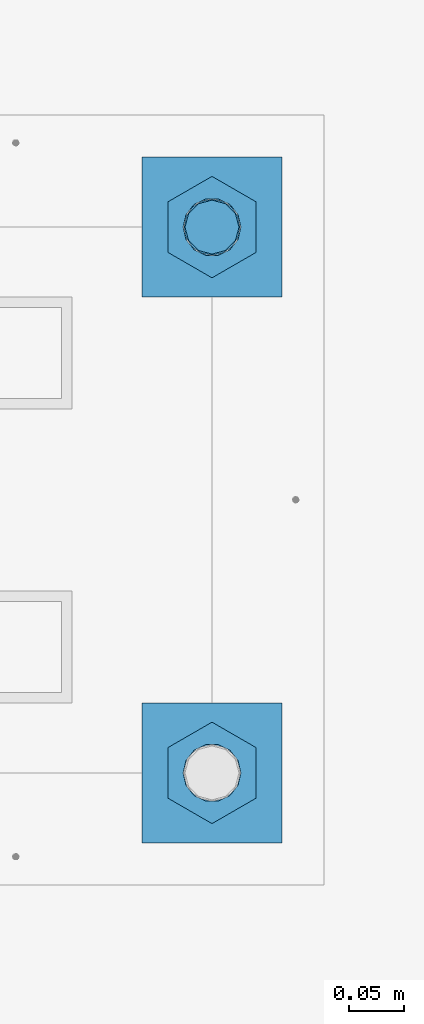
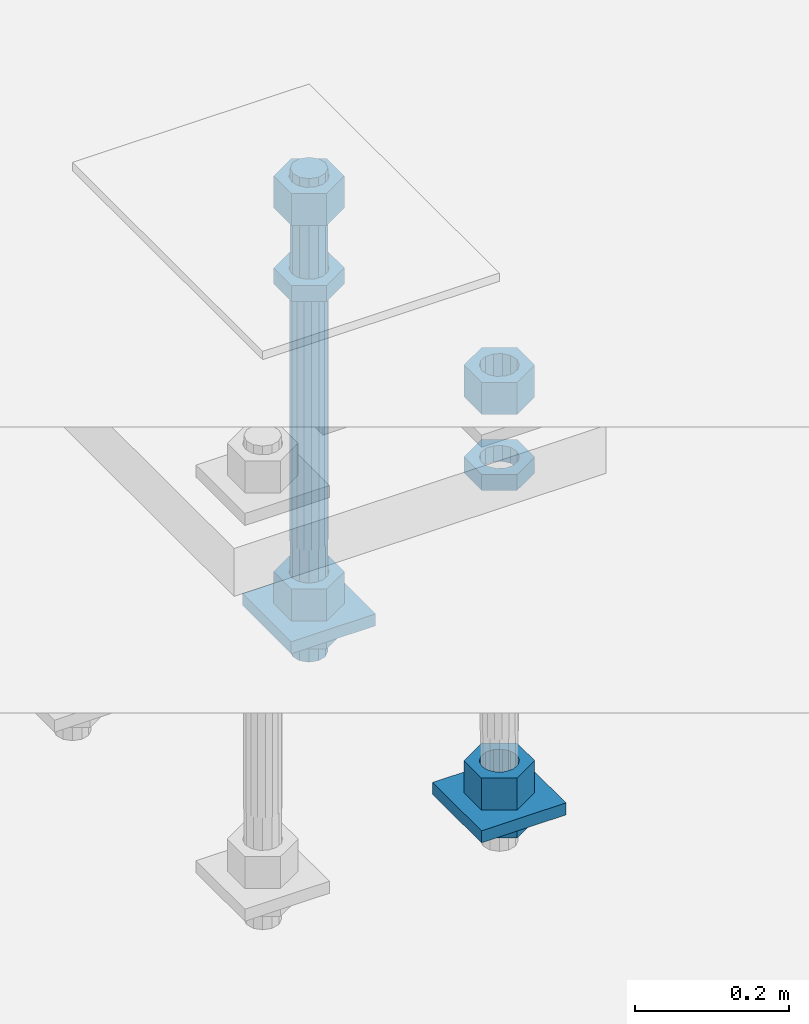
# One storey, part 2621 of 3843: 11 beams, 1 element without a shape of its own.
"""IFC2X3 building model written with IfcOpenShell, lengths in millimetres."""

from ifc_helpers import new_model, si_unit, frame, origin_with_axes, place, context, subcontext, project, spatial, faceted_brep, material, type_object, element, aggregate, save


model = new_model("IFC2X3")

# Units and contexts
model_context = context("Model", 3, precision=1e-05, world=origin_with_axes())
body_context = subcontext(model_context, "Body", "Model", "MODEL_VIEW")
ifc_project = project(units=[si_unit("LENGTHUNIT", "METRE", prefix="MILLI"), si_unit("AREAUNIT", "SQUARE_METRE"), si_unit("VOLUMEUNIT", "CUBIC_METRE"), si_unit("MASSUNIT", "GRAM", prefix="KILO"), si_unit("TIMEUNIT", "SECOND"), si_unit("PLANEANGLEUNIT", "RADIAN"), si_unit("SOLIDANGLEUNIT", "STERADIAN"), si_unit("THERMODYNAMICTEMPERATUREUNIT", "DEGREE_CELSIUS"), si_unit("LUMINOUSINTENSITYUNIT", "LUMEN")], contexts=[model_context])

# Site, building, storey
site_placement = place(None, origin_with_axes())
site = spatial("IfcSite", under=ifc_project, at=site_placement, CompositionType="ELEMENT")
building_placement = place(site_placement, origin_with_axes())
building = spatial("IfcBuilding", under=site, at=building_placement, Name="Undefined", CompositionType="ELEMENT")
storey_placement = place(building_placement, origin_with_axes())
storey = spatial("IfcBuildingStorey", under=building, at=storey_placement, Name="Undefined", CompositionType="ELEMENT", Elevation=0.0)

# Assembly, beams
assembly_placement = place(storey_placement, origin_with_axes())
assembly = element("IfcElementAssembly", 1, at=assembly_placement, inside=storey, Name="TEMPLATE", AssemblyPlace="NOTDEFINED", PredefinedType="RIGID_FRAME")
ifc_material_1 = material(Name="STEEL/A572-50")
beam_type_1 = type_object("IfcBeamType", PredefinedType="NOTDEFINED")
beam_1_placement = place(assembly_placement, frame((116217.700001526, 247.649999999994, 29244.925), z_axis=(0.0, -1.0, 0.0), x_axis=(1.0, 0.0, 0.0)))
beam_1 = element("IfcBeam", 2, at=beam_1_placement, type_object=beam_type_1, material=ifc_material_1, Name="WASHER_PLATE", context=body_context, shape_type="Brep", body=[
    faceted_brep([(0.0, 9.52500000000146, -63.5), (0.0, 9.52500000000146, 63.5), (127.0, 9.52500000000146, 63.5), (127.0, 9.52500000000146, -63.5), (0.0, -9.52500000000146, 63.5), (127.0, -9.52500000000146, 63.5), (0.0, -9.52500000000146, -63.5), (127.0, -9.52500000000146, -63.5)], [[[0, 1, 2, 3]], [[1, 4, 5, 2]], [[4, 6, 7, 5]], [[6, 0, 3, 7]], [[5, 7, 3, 2]], [[6, 4, 1, 0]]]),
])
beam_2_placement = place(assembly_placement, frame((116217.700001526, -247.649999999994, 29244.925), z_axis=(0.0, -1.0, 0.0), x_axis=(1.0, 0.0, 0.0)))
beam_2 = element("IfcBeam", 3, at=beam_2_placement, type_object=beam_type_1, material=ifc_material_1, Name="WASHER_PLATE", context=body_context, shape_type="Brep", body=[
    faceted_brep([(0.0, 9.52500000000146, -63.5), (0.0, 9.52500000000146, 63.5), (127.0, 9.52500000000146, 63.5), (127.0, 9.52500000000146, -63.5), (0.0, -9.52500000000146, 63.5), (127.0, -9.52500000000146, 63.5), (0.0, -9.52500000000146, -63.5), (127.0, -9.52500000000146, -63.5)], [[[0, 1, 2, 3]], [[1, 4, 5, 2]], [[4, 6, 7, 5]], [[6, 0, 3, 7]], [[5, 7, 3, 2]], [[6, 4, 1, 0]]]),
])
ifc_material_2 = material(Name="STEEL/A36")
beam_type_2 = type_object("IfcBeamType", Name="2_HALF_NUT", PredefinedType="NOTDEFINED")
beam_3_placement = place(assembly_placement, frame((116281.200001526, 247.649999999994, 29787.85), z_axis=(1.0, 0.0, 0.0), x_axis=(0.0, 0.0, -1.0)))
beam_3 = element("IfcBeam", 4, at=beam_3_placement, type_object=beam_type_2, material=ifc_material_2, Name="NUT", ObjectType="2_HALF_NUT", context=body_context, shape_type="Brep", body=[
    faceted_brep([(0.0, -46.0369987487793, 0.0), (0.0, -23.0184993743896, -39.869213104248), (25.4000000000015, -23.0184993743896, -39.869213104248), (25.4000000000015, -46.0369987487793, 0.0), (0.0, 23.0184993743896, -39.869213104248), (25.4000000000015, 23.0184993743896, -39.869213104248), (0.0, 46.0369987487793, 0.0), (25.4000000000015, 46.0369987487793, 0.0), (0.0, 23.0184993743896, 39.869213104248), (25.4000000000015, 23.0184993743896, 39.869213104248), (0.0, -23.0184993743896, 39.869213104248), (25.4000000000015, -23.0184993743896, 39.869213104248), (0.0, 0.0, 26.1940002441406), (0.0, 11.3650617044477, 23.5999013092805), (25.4000000000015, 11.3650617044477, 23.5999013092805), (25.4000000000015, 0.0, 26.1940002441406), (0.0, 20.4791109456419, 16.3316083006721), (25.4000000000015, 20.4791109456419, 16.3316083006721), (0.0, 25.5370200498292, 5.82867859874386), (25.4000000000015, 25.5370200498292, 5.82867859874386), (0.0, 25.5370200498292, -5.82867859874386), (25.4000000000015, 25.5370200498292, -5.82867859874386), (0.0, 20.4791109456419, -16.3316083006721), (25.4000000000015, 20.4791109456419, -16.3316083006721), (0.0, 11.3650617044477, -23.5999013092805), (25.4000000000015, 11.3650617044477, -23.5999013092805), (0.0, 0.0, -26.1940002441406), (25.4000000000015, 0.0, -26.1940002441406), (0.0, -11.3650617044477, -23.5999013092805), (25.4000000000015, -11.3650617044477, -23.5999013092805), (0.0, -20.4791109456419, -16.3316083006721), (25.4000000000015, -20.4791109456419, -16.3316083006721), (0.0, -25.5370200498292, -5.82867859874386), (25.4000000000015, -25.5370200498292, -5.82867859874386), (0.0, -25.5370200498292, 5.82867859874386), (25.4000000000015, -25.5370200498292, 5.82867859874386), (0.0, -20.4791109456419, 16.3316083006721), (25.4000000000015, -20.4791109456419, 16.3316083006721), (0.0, -11.3650617044477, 23.5999013092805), (25.4000000000015, -11.3650617044477, 23.5999013092805)], [[[0, 1, 2, 3]], [[1, 4, 5, 2]], [[4, 6, 7, 5]], [[6, 8, 9, 7]], [[8, 10, 11, 9]], [[10, 0, 3, 11]], [[12, 13, 14, 15]], [[13, 16, 17, 14]], [[16, 18, 19, 17]], [[18, 20, 21, 19]], [[20, 22, 23, 21]], [[22, 24, 25, 23]], [[24, 26, 27, 25]], [[26, 28, 29, 27]], [[28, 30, 31, 29]], [[30, 32, 33, 31]], [[32, 34, 35, 33]], [[34, 36, 37, 35]], [[36, 38, 39, 37]], [[38, 12, 15, 39]], [[5, 7, 9, 11, 3, 2], [17, 19, 21, 23, 25, 27, 29, 31, 33, 35, 37, 39, 15, 14]], [[10, 8, 6, 4, 1, 0], [38, 36, 34, 32, 30, 28, 26, 24, 22, 20, 18, 16, 13, 12]]]),
])
beam_4_placement = place(assembly_placement, frame((116281.200001526, 247.649999999994, 29235.4), z_axis=(1.0, 0.0, 0.0), x_axis=(0.0, 0.0, -1.0)))
beam_4 = element("IfcBeam", 5, at=beam_4_placement, type_object=beam_type_2, material=ifc_material_2, Name="NUT", ObjectType="2_HALF_NUT", context=body_context, shape_type="Brep", body=[
    faceted_brep([(0.0, -46.0369987487793, 0.0), (0.0, -23.0184993743896, -39.869213104248), (25.4000000000015, -23.0184993743896, -39.869213104248), (25.4000000000015, -46.0369987487793, 0.0), (0.0, 23.0184993743896, -39.869213104248), (25.4000000000015, 23.0184993743896, -39.869213104248), (0.0, 46.0369987487793, 0.0), (25.4000000000015, 46.0369987487793, 0.0), (0.0, 23.0184993743896, 39.869213104248), (25.4000000000015, 23.0184993743896, 39.869213104248), (0.0, -23.0184993743896, 39.869213104248), (25.4000000000015, -23.0184993743896, 39.869213104248), (0.0, 0.0, 26.1940002441406), (0.0, 11.3650617044477, 23.5999013092805), (25.4000000000015, 11.3650617044477, 23.5999013092805), (25.4000000000015, 0.0, 26.1940002441406), (0.0, 20.4791109456419, 16.3316083006721), (25.4000000000015, 20.4791109456419, 16.3316083006721), (0.0, 25.5370200498292, 5.82867859874386), (25.4000000000015, 25.5370200498292, 5.82867859874386), (0.0, 25.5370200498292, -5.82867859874386), (25.4000000000015, 25.5370200498292, -5.82867859874386), (0.0, 20.4791109456419, -16.3316083006721), (25.4000000000015, 20.4791109456419, -16.3316083006721), (0.0, 11.3650617044477, -23.5999013092805), (25.4000000000015, 11.3650617044477, -23.5999013092805), (0.0, 0.0, -26.1940002441406), (25.4000000000015, 0.0, -26.1940002441406), (0.0, -11.3650617044477, -23.5999013092805), (25.4000000000015, -11.3650617044477, -23.5999013092805), (0.0, -20.4791109456419, -16.3316083006721), (25.4000000000015, -20.4791109456419, -16.3316083006721), (0.0, -25.5370200498292, -5.82867859874386), (25.4000000000015, -25.5370200498292, -5.82867859874386), (0.0, -25.5370200498292, 5.82867859874386), (25.4000000000015, -25.5370200498292, 5.82867859874386), (0.0, -20.4791109456419, 16.3316083006721), (25.4000000000015, -20.4791109456419, 16.3316083006721), (0.0, -11.3650617044477, 23.5999013092805), (25.4000000000015, -11.3650617044477, 23.5999013092805)], [[[0, 1, 2, 3]], [[1, 4, 5, 2]], [[4, 6, 7, 5]], [[6, 8, 9, 7]], [[8, 10, 11, 9]], [[10, 0, 3, 11]], [[12, 13, 14, 15]], [[13, 16, 17, 14]], [[16, 18, 19, 17]], [[18, 20, 21, 19]], [[20, 22, 23, 21]], [[22, 24, 25, 23]], [[24, 26, 27, 25]], [[26, 28, 29, 27]], [[28, 30, 31, 29]], [[30, 32, 33, 31]], [[32, 34, 35, 33]], [[34, 36, 37, 35]], [[36, 38, 39, 37]], [[38, 12, 15, 39]], [[5, 7, 9, 11, 3, 2], [17, 19, 21, 23, 25, 27, 29, 31, 33, 35, 37, 39, 15, 14]], [[10, 8, 6, 4, 1, 0], [38, 36, 34, 32, 30, 28, 26, 24, 22, 20, 18, 16, 13, 12]]]),
])
beam_5_placement = place(assembly_placement, frame((116281.200001526, -247.649999999994, 29787.85), z_axis=(1.0, 0.0, 0.0), x_axis=(0.0, 0.0, -1.0)))
beam_5 = element("IfcBeam", 6, at=beam_5_placement, type_object=beam_type_2, material=ifc_material_2, Name="NUT", ObjectType="2_HALF_NUT", context=body_context, shape_type="Brep", body=[
    faceted_brep([(0.0, -46.0369987487793, 0.0), (0.0, -23.0184993743896, -39.869213104248), (25.4000000000015, -23.0184993743896, -39.869213104248), (25.4000000000015, -46.0369987487793, 0.0), (0.0, 23.0184993743896, -39.869213104248), (25.4000000000015, 23.0184993743896, -39.869213104248), (0.0, 46.0369987487793, 0.0), (25.4000000000015, 46.0369987487793, 0.0), (0.0, 23.0184993743896, 39.869213104248), (25.4000000000015, 23.0184993743896, 39.869213104248), (0.0, -23.0184993743896, 39.869213104248), (25.4000000000015, -23.0184993743896, 39.869213104248), (0.0, 0.0, 26.1940002441406), (0.0, 11.3650617044477, 23.5999013092805), (25.4000000000015, 11.3650617044477, 23.5999013092805), (25.4000000000015, 0.0, 26.1940002441406), (0.0, 20.4791109456419, 16.3316083006721), (25.4000000000015, 20.4791109456419, 16.3316083006721), (0.0, 25.5370200498292, 5.82867859874386), (25.4000000000015, 25.5370200498292, 5.82867859874386), (0.0, 25.5370200498292, -5.82867859874386), (25.4000000000015, 25.5370200498292, -5.82867859874386), (0.0, 20.4791109456419, -16.3316083006721), (25.4000000000015, 20.4791109456419, -16.3316083006721), (0.0, 11.3650617044477, -23.5999013092805), (25.4000000000015, 11.3650617044477, -23.5999013092805), (0.0, 0.0, -26.1940002441406), (25.4000000000015, 0.0, -26.1940002441406), (0.0, -11.3650617044477, -23.5999013092805), (25.4000000000015, -11.3650617044477, -23.5999013092805), (0.0, -20.4791109456419, -16.3316083006721), (25.4000000000015, -20.4791109456419, -16.3316083006721), (0.0, -25.5370200498292, -5.82867859874386), (25.4000000000015, -25.5370200498292, -5.82867859874386), (0.0, -25.5370200498292, 5.82867859874386), (25.4000000000015, -25.5370200498292, 5.82867859874386), (0.0, -20.4791109456419, 16.3316083006721), (25.4000000000015, -20.4791109456419, 16.3316083006721), (0.0, -11.3650617044477, 23.5999013092805), (25.4000000000015, -11.3650617044477, 23.5999013092805)], [[[0, 1, 2, 3]], [[1, 4, 5, 2]], [[4, 6, 7, 5]], [[6, 8, 9, 7]], [[8, 10, 11, 9]], [[10, 0, 3, 11]], [[12, 13, 14, 15]], [[13, 16, 17, 14]], [[16, 18, 19, 17]], [[18, 20, 21, 19]], [[20, 22, 23, 21]], [[22, 24, 25, 23]], [[24, 26, 27, 25]], [[26, 28, 29, 27]], [[28, 30, 31, 29]], [[30, 32, 33, 31]], [[32, 34, 35, 33]], [[34, 36, 37, 35]], [[36, 38, 39, 37]], [[38, 12, 15, 39]], [[5, 7, 9, 11, 3, 2], [17, 19, 21, 23, 25, 27, 29, 31, 33, 35, 37, 39, 15, 14]], [[10, 8, 6, 4, 1, 0], [38, 36, 34, 32, 30, 28, 26, 24, 22, 20, 18, 16, 13, 12]]]),
])
beam_6_placement = place(assembly_placement, frame((116281.200001526, -247.649999999994, 29235.4), z_axis=(1.0, 0.0, 0.0), x_axis=(0.0, 0.0, -1.0)))
beam_6 = element("IfcBeam", 7, at=beam_6_placement, type_object=beam_type_2, material=ifc_material_2, Name="NUT", ObjectType="2_HALF_NUT", context=body_context, shape_type="Brep", body=[
    faceted_brep([(0.0, -46.0369987487793, 0.0), (0.0, -23.0184993743896, -39.869213104248), (25.4000000000015, -23.0184993743896, -39.869213104248), (25.4000000000015, -46.0369987487793, 0.0), (0.0, 23.0184993743896, -39.869213104248), (25.4000000000015, 23.0184993743896, -39.869213104248), (0.0, 46.0369987487793, 0.0), (25.4000000000015, 46.0369987487793, 0.0), (0.0, 23.0184993743896, 39.869213104248), (25.4000000000015, 23.0184993743896, 39.869213104248), (0.0, -23.0184993743896, 39.869213104248), (25.4000000000015, -23.0184993743896, 39.869213104248), (0.0, 0.0, 26.1940002441406), (0.0, 11.3650617044477, 23.5999013092805), (25.4000000000015, 11.3650617044477, 23.5999013092805), (25.4000000000015, 0.0, 26.1940002441406), (0.0, 20.4791109456419, 16.3316083006721), (25.4000000000015, 20.4791109456419, 16.3316083006721), (0.0, 25.5370200498292, 5.82867859874386), (25.4000000000015, 25.5370200498292, 5.82867859874386), (0.0, 25.5370200498292, -5.82867859874386), (25.4000000000015, 25.5370200498292, -5.82867859874386), (0.0, 20.4791109456419, -16.3316083006721), (25.4000000000015, 20.4791109456419, -16.3316083006721), (0.0, 11.3650617044477, -23.5999013092805), (25.4000000000015, 11.3650617044477, -23.5999013092805), (0.0, 0.0, -26.1940002441406), (25.4000000000015, 0.0, -26.1940002441406), (0.0, -11.3650617044477, -23.5999013092805), (25.4000000000015, -11.3650617044477, -23.5999013092805), (0.0, -20.4791109456419, -16.3316083006721), (25.4000000000015, -20.4791109456419, -16.3316083006721), (0.0, -25.5370200498292, -5.82867859874386), (25.4000000000015, -25.5370200498292, -5.82867859874386), (0.0, -25.5370200498292, 5.82867859874386), (25.4000000000015, -25.5370200498292, 5.82867859874386), (0.0, -20.4791109456419, 16.3316083006721), (25.4000000000015, -20.4791109456419, 16.3316083006721), (0.0, -11.3650617044477, 23.5999013092805), (25.4000000000015, -11.3650617044477, 23.5999013092805)], [[[0, 1, 2, 3]], [[1, 4, 5, 2]], [[4, 6, 7, 5]], [[6, 8, 9, 7]], [[8, 10, 11, 9]], [[10, 0, 3, 11]], [[12, 13, 14, 15]], [[13, 16, 17, 14]], [[16, 18, 19, 17]], [[18, 20, 21, 19]], [[20, 22, 23, 21]], [[22, 24, 25, 23]], [[24, 26, 27, 25]], [[26, 28, 29, 27]], [[28, 30, 31, 29]], [[30, 32, 33, 31]], [[32, 34, 35, 33]], [[34, 36, 37, 35]], [[36, 38, 39, 37]], [[38, 12, 15, 39]], [[5, 7, 9, 11, 3, 2], [17, 19, 21, 23, 25, 27, 29, 31, 33, 35, 37, 39, 15, 14]], [[10, 8, 6, 4, 1, 0], [38, 36, 34, 32, 30, 28, 26, 24, 22, 20, 18, 16, 13, 12]]]),
])
beam_type_3 = type_object("IfcBeamType", Name="2_HEAVY_HEX_NUT", PredefinedType="NOTDEFINED")
beam_7_placement = place(assembly_placement, frame((116281.200001526, 247.649999999994, 29933.9), z_axis=(1.0, 0.0, 0.0), x_axis=(0.0, 0.0, -1.0)))
beam_7 = element("IfcBeam", 8, at=beam_7_placement, type_object=beam_type_3, material=ifc_material_2, Name="NUT", ObjectType="2_HEAVY_HEX_NUT", context=body_context, shape_type="Brep", body=[
    faceted_brep([(0.0, -46.0369987487793, 0.0), (0.0, -23.0184993743896, -39.869213104248), (50.7999999999993, -23.0184993743896, -39.869213104248), (50.7999999999993, -46.0369987487793, 0.0), (0.0, 23.0184993743896, -39.869213104248), (50.7999999999993, 23.0184993743896, -39.869213104248), (0.0, 46.0369987487793, 0.0), (50.7999999999993, 46.0369987487793, 0.0), (0.0, 23.0184993743896, 39.869213104248), (50.7999999999993, 23.0184993743896, 39.869213104248), (0.0, -23.0184993743896, 39.869213104248), (50.7999999999993, -23.0184993743896, 39.869213104248), (0.0, 0.0, 26.1940002441406), (0.0, 11.3650617044477, 23.5999013092805), (50.7999999999993, 11.3650617044477, 23.5999013092805), (50.7999999999993, 0.0, 26.1940002441406), (0.0, 20.4791109456419, 16.3316083006721), (50.7999999999993, 20.4791109456419, 16.3316083006721), (0.0, 25.5370200498292, 5.82867859874386), (50.7999999999993, 25.5370200498292, 5.82867859874386), (0.0, 25.5370200498292, -5.82867859874386), (50.7999999999993, 25.5370200498292, -5.82867859874386), (0.0, 20.4791109456419, -16.3316083006721), (50.7999999999993, 20.4791109456419, -16.3316083006721), (0.0, 11.3650617044477, -23.5999013092805), (50.7999999999993, 11.3650617044477, -23.5999013092805), (0.0, 0.0, -26.1940002441406), (50.7999999999993, 0.0, -26.1940002441406), (0.0, -11.3650617044477, -23.5999013092805), (50.7999999999993, -11.3650617044477, -23.5999013092805), (0.0, -20.4791109456419, -16.3316083006721), (50.7999999999993, -20.4791109456419, -16.3316083006721), (0.0, -25.5370200498292, -5.82867859874386), (50.7999999999993, -25.5370200498292, -5.82867859874386), (0.0, -25.5370200498292, 5.82867859874386), (50.7999999999993, -25.5370200498292, 5.82867859874386), (0.0, -20.4791109456419, 16.3316083006721), (50.7999999999993, -20.4791109456419, 16.3316083006721), (0.0, -11.3650617044477, 23.5999013092805), (50.7999999999993, -11.3650617044477, 23.5999013092805)], [[[0, 1, 2, 3]], [[1, 4, 5, 2]], [[4, 6, 7, 5]], [[6, 8, 9, 7]], [[8, 10, 11, 9]], [[10, 0, 3, 11]], [[12, 13, 14, 15]], [[13, 16, 17, 14]], [[16, 18, 19, 17]], [[18, 20, 21, 19]], [[20, 22, 23, 21]], [[22, 24, 25, 23]], [[24, 26, 27, 25]], [[26, 28, 29, 27]], [[28, 30, 31, 29]], [[30, 32, 33, 31]], [[32, 34, 35, 33]], [[34, 36, 37, 35]], [[36, 38, 39, 37]], [[38, 12, 15, 39]], [[5, 7, 9, 11, 3, 2], [17, 19, 21, 23, 25, 27, 29, 31, 33, 35, 37, 39, 15, 14]], [[10, 8, 6, 4, 1, 0], [38, 36, 34, 32, 30, 28, 26, 24, 22, 20, 18, 16, 13, 12]]]),
])
beam_8_placement = place(assembly_placement, frame((116281.200001526, 247.649999999994, 29305.25), z_axis=(1.0, 0.0, 0.0), x_axis=(0.0, 0.0, -1.0)))
beam_8 = element("IfcBeam", 9, at=beam_8_placement, type_object=beam_type_3, material=ifc_material_2, Name="NUT", ObjectType="2_HEAVY_HEX_NUT", context=body_context, shape_type="Brep", body=[
    faceted_brep([(0.0, -46.0369987487793, 0.0), (0.0, -23.0184993743896, -39.869213104248), (50.7999999999993, -23.0184993743896, -39.869213104248), (50.7999999999993, -46.0369987487793, 0.0), (0.0, 23.0184993743896, -39.869213104248), (50.7999999999993, 23.0184993743896, -39.869213104248), (0.0, 46.0369987487793, 0.0), (50.7999999999993, 46.0369987487793, 0.0), (0.0, 23.0184993743896, 39.869213104248), (50.7999999999993, 23.0184993743896, 39.869213104248), (0.0, -23.0184993743896, 39.869213104248), (50.7999999999993, -23.0184993743896, 39.869213104248), (0.0, 0.0, 26.1940002441406), (0.0, 11.3650617044477, 23.5999013092805), (50.7999999999993, 11.3650617044477, 23.5999013092805), (50.7999999999993, 0.0, 26.1940002441406), (0.0, 20.4791109456419, 16.3316083006721), (50.7999999999993, 20.4791109456419, 16.3316083006721), (0.0, 25.5370200498292, 5.82867859874386), (50.7999999999993, 25.5370200498292, 5.82867859874386), (0.0, 25.5370200498292, -5.82867859874386), (50.7999999999993, 25.5370200498292, -5.82867859874386), (0.0, 20.4791109456419, -16.3316083006721), (50.7999999999993, 20.4791109456419, -16.3316083006721), (0.0, 11.3650617044477, -23.5999013092805), (50.7999999999993, 11.3650617044477, -23.5999013092805), (0.0, 0.0, -26.1940002441406), (50.7999999999993, 0.0, -26.1940002441406), (0.0, -11.3650617044477, -23.5999013092805), (50.7999999999993, -11.3650617044477, -23.5999013092805), (0.0, -20.4791109456419, -16.3316083006721), (50.7999999999993, -20.4791109456419, -16.3316083006721), (0.0, -25.5370200498292, -5.82867859874386), (50.7999999999993, -25.5370200498292, -5.82867859874386), (0.0, -25.5370200498292, 5.82867859874386), (50.7999999999993, -25.5370200498292, 5.82867859874386), (0.0, -20.4791109456419, 16.3316083006721), (50.7999999999993, -20.4791109456419, 16.3316083006721), (0.0, -11.3650617044477, 23.5999013092805), (50.7999999999993, -11.3650617044477, 23.5999013092805)], [[[0, 1, 2, 3]], [[1, 4, 5, 2]], [[4, 6, 7, 5]], [[6, 8, 9, 7]], [[8, 10, 11, 9]], [[10, 0, 3, 11]], [[12, 13, 14, 15]], [[13, 16, 17, 14]], [[16, 18, 19, 17]], [[18, 20, 21, 19]], [[20, 22, 23, 21]], [[22, 24, 25, 23]], [[24, 26, 27, 25]], [[26, 28, 29, 27]], [[28, 30, 31, 29]], [[30, 32, 33, 31]], [[32, 34, 35, 33]], [[34, 36, 37, 35]], [[36, 38, 39, 37]], [[38, 12, 15, 39]], [[5, 7, 9, 11, 3, 2], [17, 19, 21, 23, 25, 27, 29, 31, 33, 35, 37, 39, 15, 14]], [[10, 8, 6, 4, 1, 0], [38, 36, 34, 32, 30, 28, 26, 24, 22, 20, 18, 16, 13, 12]]]),
])
beam_9_placement = place(assembly_placement, frame((116281.200001526, -247.649999999994, 29933.9), z_axis=(1.0, 0.0, 0.0), x_axis=(0.0, 0.0, -1.0)))
beam_9 = element("IfcBeam", 10, at=beam_9_placement, type_object=beam_type_3, material=ifc_material_2, Name="NUT", ObjectType="2_HEAVY_HEX_NUT", context=body_context, shape_type="Brep", body=[
    faceted_brep([(0.0, -46.0369987487793, 0.0), (0.0, -23.0184993743896, -39.869213104248), (50.7999999999993, -23.0184993743896, -39.869213104248), (50.7999999999993, -46.0369987487793, 0.0), (0.0, 23.0184993743896, -39.869213104248), (50.7999999999993, 23.0184993743896, -39.869213104248), (0.0, 46.0369987487793, 0.0), (50.7999999999993, 46.0369987487793, 0.0), (0.0, 23.0184993743896, 39.869213104248), (50.7999999999993, 23.0184993743896, 39.869213104248), (0.0, -23.0184993743896, 39.869213104248), (50.7999999999993, -23.0184993743896, 39.869213104248), (0.0, 0.0, 26.1940002441406), (0.0, 11.3650617044477, 23.5999013092805), (50.7999999999993, 11.3650617044477, 23.5999013092805), (50.7999999999993, 0.0, 26.1940002441406), (0.0, 20.4791109456419, 16.3316083006721), (50.7999999999993, 20.4791109456419, 16.3316083006721), (0.0, 25.5370200498292, 5.82867859874386), (50.7999999999993, 25.5370200498292, 5.82867859874386), (0.0, 25.5370200498292, -5.82867859874386), (50.7999999999993, 25.5370200498292, -5.82867859874386), (0.0, 20.4791109456419, -16.3316083006721), (50.7999999999993, 20.4791109456419, -16.3316083006721), (0.0, 11.3650617044477, -23.5999013092805), (50.7999999999993, 11.3650617044477, -23.5999013092805), (0.0, 0.0, -26.1940002441406), (50.7999999999993, 0.0, -26.1940002441406), (0.0, -11.3650617044477, -23.5999013092805), (50.7999999999993, -11.3650617044477, -23.5999013092805), (0.0, -20.4791109456419, -16.3316083006721), (50.7999999999993, -20.4791109456419, -16.3316083006721), (0.0, -25.5370200498292, -5.82867859874386), (50.7999999999993, -25.5370200498292, -5.82867859874386), (0.0, -25.5370200498292, 5.82867859874386), (50.7999999999993, -25.5370200498292, 5.82867859874386), (0.0, -20.4791109456419, 16.3316083006721), (50.7999999999993, -20.4791109456419, 16.3316083006721), (0.0, -11.3650617044477, 23.5999013092805), (50.7999999999993, -11.3650617044477, 23.5999013092805)], [[[0, 1, 2, 3]], [[1, 4, 5, 2]], [[4, 6, 7, 5]], [[6, 8, 9, 7]], [[8, 10, 11, 9]], [[10, 0, 3, 11]], [[12, 13, 14, 15]], [[13, 16, 17, 14]], [[16, 18, 19, 17]], [[18, 20, 21, 19]], [[20, 22, 23, 21]], [[22, 24, 25, 23]], [[24, 26, 27, 25]], [[26, 28, 29, 27]], [[28, 30, 31, 29]], [[30, 32, 33, 31]], [[32, 34, 35, 33]], [[34, 36, 37, 35]], [[36, 38, 39, 37]], [[38, 12, 15, 39]], [[5, 7, 9, 11, 3, 2], [17, 19, 21, 23, 25, 27, 29, 31, 33, 35, 37, 39, 15, 14]], [[10, 8, 6, 4, 1, 0], [38, 36, 34, 32, 30, 28, 26, 24, 22, 20, 18, 16, 13, 12]]]),
])
beam_10_placement = place(assembly_placement, frame((116281.200001526, -247.649999999994, 29305.25), z_axis=(1.0, 0.0, 0.0), x_axis=(0.0, 0.0, -1.0)))
beam_10 = element("IfcBeam", 11, at=beam_10_placement, type_object=beam_type_3, material=ifc_material_2, Name="NUT", ObjectType="2_HEAVY_HEX_NUT", context=body_context, shape_type="Brep", body=[
    faceted_brep([(0.0, -46.0369987487793, 0.0), (0.0, -23.0184993743896, -39.869213104248), (50.7999999999993, -23.0184993743896, -39.869213104248), (50.7999999999993, -46.0369987487793, 0.0), (0.0, 23.0184993743896, -39.869213104248), (50.7999999999993, 23.0184993743896, -39.869213104248), (0.0, 46.0369987487793, 0.0), (50.7999999999993, 46.0369987487793, 0.0), (0.0, 23.0184993743896, 39.869213104248), (50.7999999999993, 23.0184993743896, 39.869213104248), (0.0, -23.0184993743896, 39.869213104248), (50.7999999999993, -23.0184993743896, 39.869213104248), (0.0, 0.0, 26.1940002441406), (0.0, 11.3650617044477, 23.5999013092805), (50.7999999999993, 11.3650617044477, 23.5999013092805), (50.7999999999993, 0.0, 26.1940002441406), (0.0, 20.4791109456419, 16.3316083006721), (50.7999999999993, 20.4791109456419, 16.3316083006721), (0.0, 25.5370200498292, 5.82867859874386), (50.7999999999993, 25.5370200498292, 5.82867859874386), (0.0, 25.5370200498292, -5.82867859874386), (50.7999999999993, 25.5370200498292, -5.82867859874386), (0.0, 20.4791109456419, -16.3316083006721), (50.7999999999993, 20.4791109456419, -16.3316083006721), (0.0, 11.3650617044477, -23.5999013092805), (50.7999999999993, 11.3650617044477, -23.5999013092805), (0.0, 0.0, -26.1940002441406), (50.7999999999993, 0.0, -26.1940002441406), (0.0, -11.3650617044477, -23.5999013092805), (50.7999999999993, -11.3650617044477, -23.5999013092805), (0.0, -20.4791109456419, -16.3316083006721), (50.7999999999993, -20.4791109456419, -16.3316083006721), (0.0, -25.5370200498292, -5.82867859874386), (50.7999999999993, -25.5370200498292, -5.82867859874386), (0.0, -25.5370200498292, 5.82867859874386), (50.7999999999993, -25.5370200498292, 5.82867859874386), (0.0, -20.4791109456419, 16.3316083006721), (50.7999999999993, -20.4791109456419, 16.3316083006721), (0.0, -11.3650617044477, 23.5999013092805), (50.7999999999993, -11.3650617044477, 23.5999013092805)], [[[0, 1, 2, 3]], [[1, 4, 5, 2]], [[4, 6, 7, 5]], [[6, 8, 9, 7]], [[8, 10, 11, 9]], [[10, 0, 3, 11]], [[12, 13, 14, 15]], [[13, 16, 17, 14]], [[16, 18, 19, 17]], [[18, 20, 21, 19]], [[20, 22, 23, 21]], [[22, 24, 25, 23]], [[24, 26, 27, 25]], [[26, 28, 29, 27]], [[28, 30, 31, 29]], [[30, 32, 33, 31]], [[32, 34, 35, 33]], [[34, 36, 37, 35]], [[36, 38, 39, 37]], [[38, 12, 15, 39]], [[5, 7, 9, 11, 3, 2], [17, 19, 21, 23, 25, 27, 29, 31, 33, 35, 37, 39, 15, 14]], [[10, 8, 6, 4, 1, 0], [38, 36, 34, 32, 30, 28, 26, 24, 22, 20, 18, 16, 13, 12]]]),
])
ifc_material_3 = material()
beam_type_4 = type_object("IfcBeamType", PredefinedType="NOTDEFINED")
beam_11_placement = place(assembly_placement, frame((116281.200001526, 247.649999999994, 29762.45), z_axis=(1.0, 0.0, 0.0), x_axis=(0.0, 0.0, -1.0)))
beam_11 = element("IfcBeam", 12, at=beam_11_placement, type_object=beam_type_4, material=ifc_material_3, Name="ANCHOR_ROD", context=body_context, shape_type="Brep", body=[
    faceted_brep([(-184.150000000001, -21.217622392709, 12.25), (-184.150000000001, -12.2499999999854, 21.2176223927163), (-184.150000000001, 1.45519152283669e-11, 24.5), (-184.150000000001, 12.2500000000146, 21.2176223927163), (-184.150000000001, 21.2176223927381, 12.25), (-184.150000000001, 24.5000000000146, 0.0), (-184.150000000001, 21.2176223927381, -12.25), (-184.150000000001, 12.2500000000146, -21.2176223927163), (-184.150000000001, 1.45519152283669e-11, -24.5), (-184.150000000001, -12.2499999999854, -21.2176223927163), (-184.150000000001, -21.217622392709, -12.25), (-184.150000000001, -24.4999999999854, 0.0), (0.0, 24.5000000000146, 0.0), (0.0, 21.2176223927381, -12.25), (0.0, 12.2500000000146, -21.2176223927163), (0.0, 1.45519152283669e-11, -24.5), (0.0, -12.2499999999854, -21.2176223927163), (0.0, -21.217622392709, -12.25), (0.0, -24.4999999999854, 0.0), (0.0, -21.217622392709, 12.25), (0.0, -12.2499999999854, 21.2176223927163), (0.0, 1.45519152283669e-11, 24.5), (0.0, 12.2500000000146, 21.2176223927163), (0.0, 21.2176223927381, 12.25), (0.0, -23.4665401257807, 9.72015918207035), (0.0, -17.9605122421344, 17.9605122421417), (0.0, -9.72015918207762, 23.466540125788), (0.0, 0.0, 25.4000000000015), (0.0, 9.72015918207762, 23.466540125788), (0.0, 17.9605122421344, 17.9605122421417), (0.0, 23.4665401257807, 9.72015918207035), (0.0, 25.3999996185303, 0.0), (0.0, 23.4665401257807, -9.72015918207035), (0.0, 17.9605122421344, -17.9605122421417), (0.0, 9.72015918207762, -23.466540125788), (0.0, 0.0, -25.4000000000015), (0.0, -9.72015918207762, -23.466540125788), (0.0, -17.9605122421344, -17.9605122421417), (0.0, -23.4665401257807, -9.72015918207035), (0.0, -25.3999996185303, 0.0), (406.399999999998, -25.3999999999942, 0.0), (406.399999999998, -23.4665401257807, 9.72015918207035), (406.399999999998, -17.9605122421344, 17.9605122421417), (406.399999999998, -9.72015918207762, 23.466540125788), (406.399999999998, 0.0, 25.4000000000015), (406.399999999998, 9.72015918207762, 23.466540125788), (406.399999999998, 17.9605122421344, 17.9605122421417), (406.399999999998, 23.4665401257807, 9.72015918207035), (406.399999999998, 25.3999999999942, 0.0), (406.399999999998, 23.4665401257807, -9.72015918207035), (406.399999999998, 17.9605122421344, -17.9605122421417), (406.399999999998, 9.72015918207762, -23.466540125788), (406.399999999998, 0.0, -25.4000000000015), (406.399999999998, -9.72015918207762, -23.466540125788), (406.399999999998, -17.9605122421344, -17.9605122421417), (406.399999999998, -23.4665401257807, -9.72015918207035), (406.399999999998, -12.2499999999854, 21.2176223927163), (406.399999999998, 1.45519152283669e-11, 24.5), (406.399999999998, 12.2500000000146, 21.2176223927163), (406.399999999998, 21.2176223927381, 12.25), (406.399999999998, 24.5000000000146, 0.0), (406.399999999998, 21.2176223927381, -12.25), (406.399999999998, 12.2500000000146, -21.2176223927163), (406.399999999998, 1.45519152283669e-11, -24.5), (406.399999999998, -12.2499999999854, -21.2176223927163), (406.399999999998, -21.217622392709, -12.25), (406.399999999998, -24.4999999999854, 0.0), (406.399999999998, -21.217622392709, 12.25), (584.200000000001, -12.2499999999854, -21.2176223927163), (584.200000000001, 1.45519152283669e-11, -24.5), (584.200000000001, 12.2500000000146, -21.2176223927163), (584.200000000001, 21.2176223927381, -12.25), (584.200000000001, 24.5000000000146, 0.0), (584.200000000001, 21.2176223927381, 12.25), (584.200000000001, 12.2500000000146, 21.2176223927163), (584.200000000001, 1.45519152283669e-11, 24.5), (584.200000000001, -12.2499999999854, 21.2176223927163), (584.200000000001, -21.217622392709, 12.25), (584.200000000001, -24.4999999999854, 0.0), (584.200000000001, -21.217622392709, -12.25)], [[[0, 1, 2, 3, 4, 5, 6, 7, 8, 9, 10, 11]], [[6, 5, 12, 13]], [[7, 6, 13, 14]], [[8, 7, 14, 15]], [[9, 8, 15, 16]], [[10, 9, 16, 17]], [[11, 10, 17, 18]], [[0, 11, 18, 19]], [[1, 0, 19, 20]], [[2, 1, 20, 21]], [[3, 2, 21, 22]], [[4, 3, 22, 23]], [[5, 4, 23, 12]], [[24, 25, 26, 27, 28, 29, 30, 31, 32, 33, 34, 35, 36, 37, 38, 39], [22, 21, 20, 19, 18, 17, 16, 15, 14, 13, 12, 23]], [[24, 39, 40, 41]], [[25, 24, 41, 42]], [[26, 25, 42, 43]], [[27, 26, 43, 44]], [[28, 27, 44, 45]], [[29, 28, 45, 46]], [[30, 29, 46, 47]], [[31, 30, 47, 48]], [[32, 31, 48, 49]], [[33, 32, 49, 50]], [[34, 33, 50, 51]], [[35, 34, 51, 52]], [[36, 35, 52, 53]], [[37, 36, 53, 54]], [[38, 37, 54, 55]], [[39, 38, 55, 40]], [[54, 53, 52, 51, 50, 49, 48, 47, 46, 45, 44, 43, 42, 41, 40, 55], [56, 57, 58, 59, 60, 61, 62, 63, 64, 65, 66, 67]], [[68, 69, 70, 71, 72, 73, 74, 75, 76, 77, 78, 79]], [[76, 75, 57, 56]], [[77, 76, 56, 67]], [[78, 77, 67, 66]], [[79, 78, 66, 65]], [[68, 79, 65, 64]], [[69, 68, 64, 63]], [[70, 69, 63, 62]], [[71, 70, 62, 61]], [[72, 71, 61, 60]], [[73, 72, 60, 59]], [[74, 73, 59, 58]], [[75, 74, 58, 57]]]),
])
aggregate(assembly, [beam_3, beam_7, beam_8, beam_4, beam_1, beam_11, beam_5, beam_9, beam_10, beam_6, beam_2])

save(model, "model.ifc")
